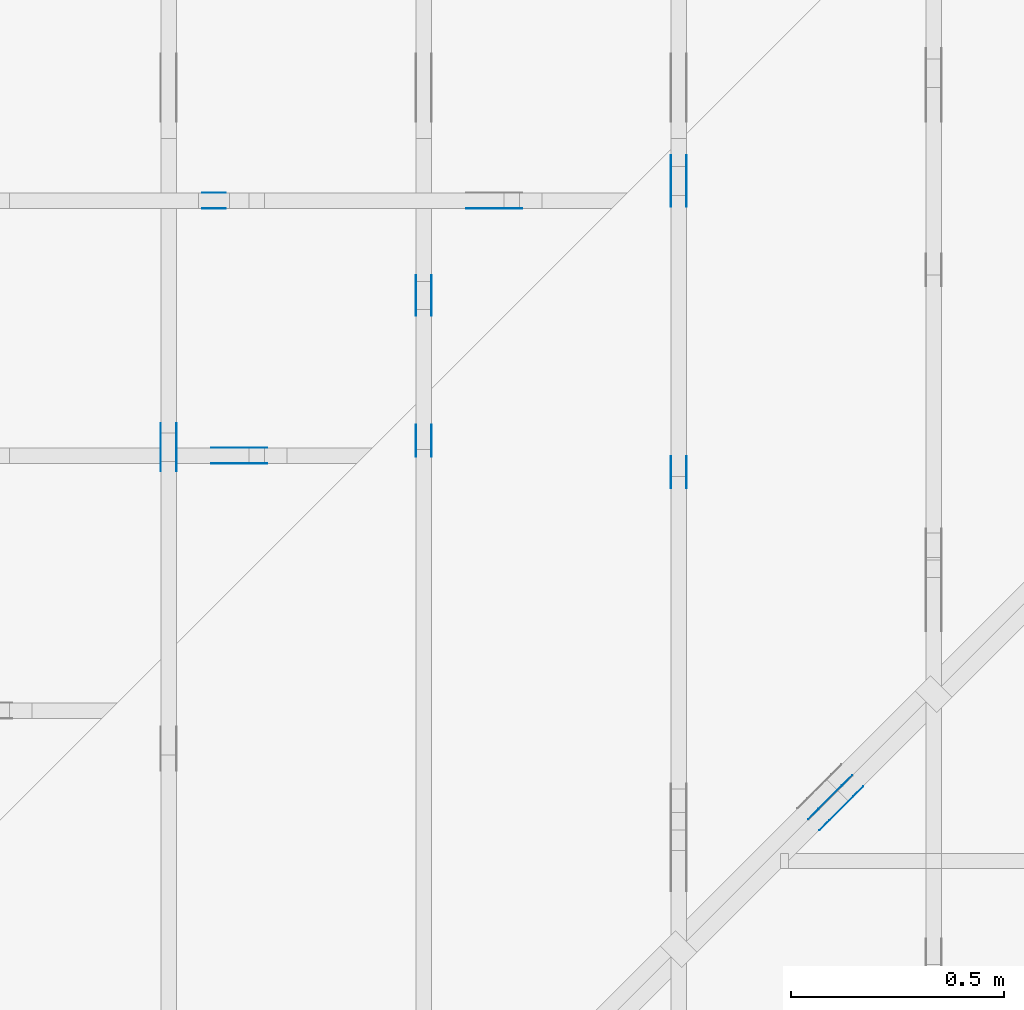
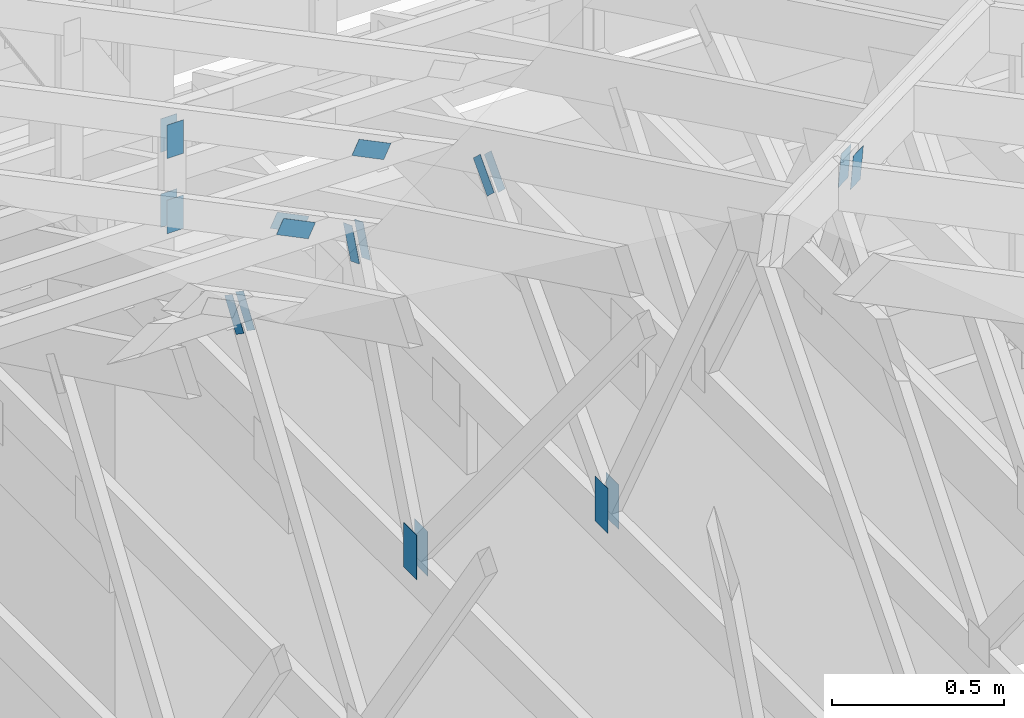
# One storey, part 122 of 159: 19 plates, 6 elements without a shape of their own.
"""IFC2X3 building model written with IfcOpenShell, lengths in millimetres."""

from ifc_helpers import new_model, si_unit, frame, origin, origin_with_axes, origin_2d, place, context, project, spatial, faceted_brep, element, aggregate, save


model = new_model("IFC2X3")

# Units and contexts
model_context = context("Model", 3, precision=1e-05, world=origin())
plan_context = context("Plan", 2, precision=1e-05, world=origin_2d())
ifc_project = project(units=[si_unit("LENGTHUNIT", "METRE", prefix="MILLI"), si_unit("AREAUNIT", "SQUARE_METRE"), si_unit("VOLUMEUNIT", "CUBIC_METRE"), si_unit("SOLIDANGLEUNIT", "STERADIAN"), si_unit("PLANEANGLEUNIT", "RADIAN"), si_unit("MASSUNIT", "GRAM"), si_unit("TIMEUNIT", "SECOND"), si_unit("THERMODYNAMICTEMPERATUREUNIT", "DEGREE_CELSIUS"), si_unit("LUMINOUSINTENSITYUNIT", "LUMEN")], contexts=[model_context, plan_context])

# Site, building, storey
site_placement = place(None, origin_with_axes())
site = spatial("IfcSite", under=ifc_project, at=site_placement, CompositionType="ELEMENT")
building_placement = place(site_placement, origin_with_axes())
building = spatial("IfcBuilding", under=site, at=building_placement, Name="Plan 1", CompositionType="ELEMENT")
storey_placement = place(building_placement, origin_with_axes())
storey = spatial("IfcBuildingStorey", under=building, at=storey_placement, Name="Etasje 1", CompositionType="ELEMENT", Elevation=0.0)

# Assembly, plates
assembly_1_placement = place(storey_placement, frame((16311.022261404749, -699.9989301294839, 1.1021457184401395e-15), z_axis=(1.0, -6.123031769111886e-17, 6.123031769111886e-17), x_axis=(6.123031769111886e-17, 1.0, 0.0)))
assembly_1 = element("IfcElementAssembly", 1, at=assembly_1_placement, inside=storey, Name="V8 (33)", AssemblyPlace="FACTORY", PredefinedType="TRUSS")
plate_1_placement = place(assembly_1_placement, frame((7426.87939453125, 291.4999999999999, 0.0), z_axis=(0.0, 0.0, 1.0), x_axis=(6.123031769111886e-17, 1.0, 0.0)))
plate_1 = element("IfcPlate", 2, at=plate_1_placement, Name="GNT100S 76x159", context=model_context, shape_type="Brep", body=[
    faceted_brep([(159.0000000000001, 76.0, 1.0), (1.1368683772161603e-13, 76.0, 1.0), (1.1368683772161603e-13, 0.0, 1.0), (159.0000000000001, 0.0, 1.0), (1.1368683772161603e-13, 76.0, 1.392216238198645e-29), (159.0000000000001, 76.0, 1.947124102577581e-14), (159.0000000000001, 0.0, 1.947124102577581e-14), (1.1368683772161603e-13, 0.0, 1.392216238198645e-29), (159.0, 5.9471509273759435e-05, 1.788345571668688e-30), (159.0, 5.9471509273820665e-05, 1.0), (1.1247455413666031e-32, 5.947150930302753e-05, 1.0), (0.0, 5.94715093029663e-05, 0.0), (159.0, 76.0000594715093, 0.0), (159.0, 76.0000594715093, 1.0), (159.0, 5.94715093029663e-05, 1.0), (159.0, 5.94715093029663e-05, 0.0), (2.4308653429145085e-63, 76.0000594715093, 0.0), (-3.7491518045553436e-33, 76.0000594715093, 1.0), (159.0, 76.00005947150929, 1.0), (159.0, 76.00005947150929, -7.888609052210118e-31), (7.282918816381915e-21, 5.94715093029663e-05, -4.45935432845692e-37), (6.123760060993524e-17, 5.94715093029663e-05, 1.0), (9.368245889660002e-15, 76.0000594715093, 1.0), (9.307015571968883e-15, 76.0000594715093, -5.698715202278451e-31)], [[[0, 1, 2, 3]], [[4, 5, 6, 7]], [[8, 9, 10, 11]], [[12, 13, 14, 15]], [[16, 17, 18, 19]], [[20, 21, 22, 23]]]),
])
plate_2_placement = place(assembly_1_placement, frame((7426.87939453125, 291.4999999999999, -37.0), z_axis=(0.0, 0.0, 1.0), x_axis=(6.123031769111886e-17, 1.0, 0.0)))
plate_2 = element("IfcPlate", 3, at=plate_2_placement, Name="GNT100S 76x159", context=model_context, shape_type="Brep", body=[
    faceted_brep([(159.0000000000001, 76.0, 1.0), (1.1368683772161603e-13, 76.0, 1.0), (1.1368683772161603e-13, 0.0, 1.0), (159.0000000000001, 0.0, 1.0), (1.1368683772161603e-13, 76.0, 1.392216238198645e-29), (159.0000000000001, 76.0, 1.947124102577581e-14), (159.0000000000001, 0.0, 1.947124102577581e-14), (1.1368683772161603e-13, 0.0, 1.392216238198645e-29), (159.0, 5.9471509273759435e-05, 1.788345571668688e-30), (159.0, 5.9471509273820665e-05, 1.0), (1.1247455413666031e-32, 5.947150930302753e-05, 1.0), (0.0, 5.94715093029663e-05, 0.0), (159.0, 76.0000594715093, 0.0), (159.0, 76.0000594715093, 1.0), (159.0, 5.94715093029663e-05, 1.0), (159.0, 5.94715093029663e-05, 0.0), (2.4308653429145085e-63, 76.0000594715093, 0.0), (-3.7491518045553436e-33, 76.0000594715093, 1.0), (159.0, 76.00005947150929, 1.0), (159.0, 76.00005947150929, -7.888609052210118e-31), (7.282918816381915e-21, 5.94715093029663e-05, -4.45935432845692e-37), (6.123760060993524e-17, 5.94715093029663e-05, 1.0), (9.368245889660002e-15, 76.0000594715093, 1.0), (9.307015571968883e-15, 76.0000594715093, -5.698715202278451e-31)], [[[0, 1, 2, 3]], [[4, 5, 6, 7]], [[8, 9, 10, 11]], [[12, 13, 14, 15]], [[16, 17, 18, 19]], [[20, 21, 22, 23]]]),
])
plate_3_placement = place(assembly_1_placement, frame((7727.3363223413935, 1322.4800851328964, 0.0), z_axis=(0.0, 0.0, 1.0), x_axis=(-0.3666406245078845, -0.9303626456712826, 0.0)))
plate_3 = element("IfcPlate", 4, at=plate_3_placement, Name="GNT100S 55x119", context=model_context, shape_type="Brep", body=[
    faceted_brep([(119.00014504609044, 55.00008577616154, 1.0), (0.0, 55.00008577616154, 1.0), (5.9450358548929216e-05, 0.00013461070739140268, 1.0), (119.00009092679011, 0.00013461070739140268, 1.0), (0.0, 55.00008577616154, 0.0), (119.00014504609044, 55.00008577616154, 1.4572833372922683e-14), (119.00009092679011, 0.0, 1.457282674543878e-14), (5.9450358548929216e-05, 0.0, 7.28032868160372e-21), (119.00002127778316, 0.00018937683582577298, -1.2175744154743796e-30), (119.00002127778316, 0.00018937683582583421, 1.0), (2.127778316207696e-05, 0.00018937683489645435, 1.0), (2.127778316207696e-05, 0.00018937683489639312, 0.0), (119.00002127778316, 55.000189376835806, 0.0), (119.00002127778316, 55.000189376835806, 1.0), (119.00002127778316, 0.00018937683580588782, 1.0), (119.00002127778316, 0.00018937683580588782, 0.0), (2.1277783162076958e-05, 55.000189376835806, 0.0), (2.1277783162076958e-05, 55.000189376835806, 1.0), (119.00002127778316, 55.0001893768358, 1.0), (119.00002127778316, 55.0001893768358, -3.944304526105059e-31), (2.127778316207698e-05, 0.00018937683489639312, -1.504632769052528e-36), (2.127778316213821e-05, 0.00018937683489639312, 1.0), (2.1277783168873547e-05, 55.000189376835806, 1.0), (2.1277783168812316e-05, 55.000189376835806, -4.124081810933378e-31)], [[[0, 1, 2, 3]], [[4, 5, 6, 7]], [[8, 9, 10, 11]], [[12, 13, 14, 15]], [[16, 17, 18, 19]], [[20, 21, 22, 23]]]),
])
plate_4_placement = place(assembly_1_placement, frame((7727.3363223413935, 1322.4800851328964, -36.99999999999999), z_axis=(0.0, 0.0, 1.0), x_axis=(-0.3666406245078845, -0.9303626456712826, 0.0)))
plate_4 = element("IfcPlate", 5, at=plate_4_placement, Name="GNT100S 55x119", context=model_context, shape_type="Brep", body=[
    faceted_brep([(119.00014504609044, 55.00008577616154, 1.0), (0.0, 55.00008577616154, 1.0), (5.9450358548929216e-05, 0.00013461070739140268, 1.0), (119.00009092679011, 0.00013461070739140268, 1.0), (0.0, 55.00008577616154, 0.0), (119.00014504609044, 55.00008577616154, 1.4572833372922683e-14), (119.00009092679011, 0.0, 1.457282674543878e-14), (5.9450358548929216e-05, 0.0, 7.28032868160372e-21), (119.00002127778316, 0.00018937683582577298, -1.2175744154743796e-30), (119.00002127778316, 0.00018937683582583421, 1.0), (2.127778316207696e-05, 0.00018937683489645435, 1.0), (2.127778316207696e-05, 0.00018937683489639312, 0.0), (119.00002127778316, 55.000189376835806, 0.0), (119.00002127778316, 55.000189376835806, 1.0), (119.00002127778316, 0.00018937683580588782, 1.0), (119.00002127778316, 0.00018937683580588782, 0.0), (2.1277783162076958e-05, 55.000189376835806, 0.0), (2.1277783162076958e-05, 55.000189376835806, 1.0), (119.00002127778316, 55.0001893768358, 1.0), (119.00002127778316, 55.0001893768358, -3.944304526105059e-31), (2.127778316207698e-05, 0.00018937683489639312, -1.504632769052528e-36), (2.127778316213821e-05, 0.00018937683489639312, 1.0), (2.1277783168873547e-05, 55.000189376835806, 1.0), (2.1277783168812316e-05, 55.000189376835806, -4.124081810933378e-31)], [[[0, 1, 2, 3]], [[4, 5, 6, 7]], [[8, 9, 10, 11]], [[12, 13, 14, 15]], [[16, 17, 18, 19]], [[20, 21, 22, 23]]]),
])
aggregate(assembly_1, [plate_1, plate_2, plate_3, plate_4])

assembly_2_placement = place(storey_placement, frame((16875.02226140475, -699.9989301294827, 1.1021457184401395e-15), z_axis=(-1.0, 1.836909530733566e-16, 6.123031769111886e-17), x_axis=(-1.836909530733566e-16, -1.0, 0.0)))
assembly_2 = element("IfcElementAssembly", 6, at=assembly_2_placement, inside=storey, Name="V7 (32)", AssemblyPlace="FACTORY", PredefinedType="TRUSS")
plate_5_placement = place(assembly_2_placement, frame((-8061.18067390642, 1150.2209577382325, 0.0), z_axis=(0.0, 0.0, 1.0), x_axis=(0.6848977524081679, -0.7286391896859791, 0.0)))
plate_5 = element("IfcPlate", 7, at=plate_5_placement, Name="GNT100S 55x119", context=model_context, shape_type="Brep", body=[
    faceted_brep([(119.00011485464893, 55.00006824185584, 1.0), (0.0, 55.00006824185584, 1.0), (1.4372830264619552e-05, 0.0, 1.0), (119.00004028226613, 0.0, 1.0), (0.0, 55.00006824185584, 0.0), (119.00011485464893, 55.00006824185584, 1.4572829675659574e-14), (119.00004028226613, 0.00010897796255449066, 1.4572820543478193e-14), (1.4372830264619552e-05, 0.00010897796255449066, 1.7601059264463663e-21), (119.0000768655018, 0.00010936123720063465, 3.8944725934268084e-30), (119.0000768655018, 0.00010936123720069588, 1.0), (7.686550179641927e-05, 0.00010936123817379419, 1.0), (7.686550179641927e-05, 0.00010936123817373296, 3.009265538105056e-36), (119.0000768655018, 55.000109361238174, 0.0), (119.0000768655018, 55.000109361238174, 1.0), (119.0000768655018, 0.0001093612372642383, 1.0), (119.0000768655018, 0.0001093612372642383, 0.0), (7.686550179641925e-05, 55.000109361237264, 0.0), (7.686550179641925e-05, 55.000109361237264, 1.0), (119.0000768655018, 55.00010936123818, 1.0), (119.0000768655018, 55.00010936123818, 3.944304526105059e-31), (7.686550179641928e-05, 0.000109361238173733, -7.52316384526264e-37), (7.686550179648051e-05, 0.000109361238173733, 1.0), (7.686550180321585e-05, 55.000109361237264, 1.0), (7.686550180315462e-05, 55.000109361237264, -4.124078049351455e-31)], [[[0, 1, 2, 3]], [[4, 5, 6, 7]], [[8, 9, 10, 11]], [[12, 13, 14, 15]], [[16, 17, 18, 19]], [[20, 21, 22, 23]]]),
])
plate_6_placement = place(assembly_2_placement, frame((-8061.18067390642, 1150.2209577382325, -37.00000000000001), z_axis=(0.0, 0.0, 1.0), x_axis=(0.6848977524081679, -0.7286391896859791, 0.0)))
plate_6 = element("IfcPlate", 8, at=plate_6_placement, Name="GNT100S 55x119", context=model_context, shape_type="Brep", body=[
    faceted_brep([(119.00011485464893, 55.00006824185584, 1.0), (0.0, 55.00006824185584, 1.0), (1.4372830264619552e-05, 0.0, 1.0), (119.00004028226613, 0.0, 1.0), (0.0, 55.00006824185584, 0.0), (119.00011485464893, 55.00006824185584, 1.4572829675659574e-14), (119.00004028226613, 0.00010897796255449066, 1.4572820543478193e-14), (1.4372830264619552e-05, 0.00010897796255449066, 1.7601059264463663e-21), (119.0000768655018, 0.00010936123720063465, 3.8944725934268084e-30), (119.0000768655018, 0.00010936123720069588, 1.0), (7.686550179641927e-05, 0.00010936123817379419, 1.0), (7.686550179641927e-05, 0.00010936123817373296, 3.009265538105056e-36), (119.0000768655018, 55.000109361238174, 0.0), (119.0000768655018, 55.000109361238174, 1.0), (119.0000768655018, 0.0001093612372642383, 1.0), (119.0000768655018, 0.0001093612372642383, 0.0), (7.686550179641925e-05, 55.000109361237264, 0.0), (7.686550179641925e-05, 55.000109361237264, 1.0), (119.0000768655018, 55.00010936123818, 1.0), (119.0000768655018, 55.00010936123818, 3.944304526105059e-31), (7.686550179641928e-05, 0.000109361238173733, -7.52316384526264e-37), (7.686550179648051e-05, 0.000109361238173733, 1.0), (7.686550180321585e-05, 55.000109361237264, 1.0), (7.686550180315462e-05, 55.000109361237264, -4.124078049351455e-31)], [[[0, 1, 2, 3]], [[4, 5, 6, 7]], [[8, 9, 10, 11]], [[12, 13, 14, 15]], [[16, 17, 18, 19]], [[20, 21, 22, 23]]]),
])
plate_7_placement = place(assembly_2_placement, frame((-7276.765625, 291.4999999999998, 0.0), z_axis=(0.0, 0.0, 1.0), x_axis=(6.123031769111886e-17, 1.0, 0.0)))
plate_7 = element("IfcPlate", 9, at=plate_7_placement, Name="GNT100S 76x159", context=model_context, shape_type="Brep", body=[
    faceted_brep([(159.00000000000023, 76.0, 1.0), (2.2737367544323206e-13, 76.0, 1.0), (2.2737367544323206e-13, 0.0, 1.0), (159.00000000000023, 0.0, 1.0), (2.2737367544323206e-13, 76.0, 2.78443247639729e-29), (159.00000000000023, 76.0, 1.9471241025775827e-14), (159.00000000000023, 0.0, 1.9471241025775827e-14), (2.2737367544323206e-13, 0.0, 2.78443247639729e-29), (159.0, 0.0001630968781390827, 1.7883448193523036e-30), (159.0, 0.00016309687813914392, 1.0), (1.1247455413666031e-32, 0.00016309687816835078, 1.0), (0.0, 0.00016309687816828955, 0.0), (159.0, 76.00016309687817, 0.0), (159.0, 76.00016309687817, 1.0), (159.0, 0.00016309687816828955, 1.0), (159.0, 0.00016309687816828955, 0.0), (0.0, 76.00016309687817, 0.0), (-3.7491518045553436e-33, 76.00016309687817, 1.0), (159.0, 76.00016309687815, 1.0), (159.0, 76.00016309687815, -7.888609052210118e-31), (1.9972947329348155e-20, 0.00016309687816828955, -1.2229499102039716e-36), (6.125029063844821e-17, 0.00016309687816828955, 1.0), (9.368258579688515e-15, 76.00016309687817, 1.0), (9.307028261997396e-15, 76.00016309687817, -5.698722972423224e-31)], [[[0, 1, 2, 3]], [[4, 5, 6, 7]], [[8, 9, 10, 11]], [[12, 13, 14, 15]], [[16, 17, 18, 19]], [[20, 21, 22, 23]]]),
])
plate_8_placement = place(assembly_2_placement, frame((-7276.765625, 291.4999999999998, -37.0), z_axis=(0.0, 0.0, 1.0), x_axis=(6.123031769111886e-17, 1.0, 0.0)))
plate_8 = element("IfcPlate", 10, at=plate_8_placement, Name="GNT100S 76x159", context=model_context, shape_type="Brep", body=[
    faceted_brep([(159.00000000000023, 76.0, 1.0), (2.2737367544323206e-13, 76.0, 1.0), (2.2737367544323206e-13, 0.0, 1.0), (159.00000000000023, 0.0, 1.0), (2.2737367544323206e-13, 76.0, 2.78443247639729e-29), (159.00000000000023, 76.0, 1.9471241025775827e-14), (159.00000000000023, 0.0, 1.9471241025775827e-14), (2.2737367544323206e-13, 0.0, 2.78443247639729e-29), (159.0, 0.0001630968781390827, 1.7883448193523036e-30), (159.0, 0.00016309687813914392, 1.0), (1.1247455413666031e-32, 0.00016309687816835078, 1.0), (0.0, 0.00016309687816828955, 0.0), (159.0, 76.00016309687817, 0.0), (159.0, 76.00016309687817, 1.0), (159.0, 0.00016309687816828955, 1.0), (159.0, 0.00016309687816828955, 0.0), (0.0, 76.00016309687817, 0.0), (-3.7491518045553436e-33, 76.00016309687817, 1.0), (159.0, 76.00016309687815, 1.0), (159.0, 76.00016309687815, -7.888609052210118e-31), (1.9972947329348155e-20, 0.00016309687816828955, -1.2229499102039716e-36), (6.125029063844821e-17, 0.00016309687816828955, 1.0), (9.368258579688515e-15, 76.00016309687817, 1.0), (9.307028261997396e-15, 76.00016309687817, -5.698722972423224e-31)], [[[0, 1, 2, 3]], [[4, 5, 6, 7]], [[8, 9, 10, 11]], [[12, 13, 14, 15]], [[16, 17, 18, 19]], [[20, 21, 22, 23]]]),
])
aggregate(assembly_2, [plate_5, plate_6, plate_7, plate_8])

assembly_3_placement = place(storey_placement, frame((21074.556818978763, 9725.45584412271, 2.204291436880279e-15), z_axis=(-0.7071067811865471, 0.7071067811865479, 6.123031769111886e-17), x_axis=(-0.7071067811865479, -0.7071067811865471, 0.0)))
assembly_3 = element("IfcElementAssembly", 11, at=assembly_3_placement, inside=storey, Name="GR1 (36)", AssemblyPlace="FACTORY", PredefinedType="TRUSS")
plate_9_placement = place(assembly_3_placement, frame((5405.349966255167, 1839.0221714793984, -35.99999999999999), z_axis=(0.0, 0.0, 1.0), x_axis=(0.9453579955214152, 0.32603413978252627, 0.0)))
plate_9 = element("IfcPlate", 12, at=plate_9_placement, Name="GNT100S 103x119", context=model_context, shape_type="Brep", body=[
    faceted_brep([(119.00006868466426, 102.99996388448972, 1.0), (9.843365569395246e-05, 102.99996388448972, 1.0), (0.0001389961080349167, 0.0, 1.0), (119.0001092471175, 0.0, 1.0), (9.843365569395246e-05, 102.99996388448972, 1.205424801927784e-20), (119.00006868466426, 102.99996388448972, 1.4572824021653914e-14), (119.0001092471175, 4.524020664575801e-05, 1.4572828988957714e-14), (0.0001389961080349167, 4.524020664575801e-05, 1.7021551705614056e-20), (119.0, 4.315270027833824e-05, 1.338447208185253e-30), (119.0, 4.315270027839947e-05, 1.0), (1.1247455413666031e-32, 4.3152700300258697e-05, 1.0), (0.0, 4.3152700300197466e-05, 0.0), (119.0, 103.0000431527003, 5.522026336547083e-29), (119.0, 103.0000431527003, 1.0), (119.0, 4.3152700300197466e-05, 1.0), (119.0, 4.3152700300197466e-05, 0.0), (0.0, 103.0000431527003, 0.0), (-3.7491518045553436e-33, 103.0000431527003, 1.0), (118.99999999999909, 103.00004315270029, 1.0), (118.99999999999909, 103.00004315270029, -7.888609052210118e-31), (5.284507097221462e-21, 4.3152700300197466e-05, -3.235720484038425e-37), (6.123560219821608e-17, 4.3152700300197466e-05, 1.0), (1.2674681046568702e-14, 103.0000431527003, 1.0), (1.2613450728877583e-14, 103.0000431527003, -7.723255953104492e-31)], [[[0, 1, 2, 3]], [[4, 5, 6, 7]], [[8, 9, 10, 11]], [[12, 13, 14, 15]], [[16, 17, 18, 19]], [[20, 21, 22, 23]]]),
])
plate_10_placement = place(assembly_3_placement, frame((5405.349966255167, 1839.0221714793984, -73.0), z_axis=(0.0, 0.0, 1.0), x_axis=(0.9453579955214152, 0.32603413978252627, 0.0)))
plate_10 = element("IfcPlate", 13, at=plate_10_placement, Name="GNT100S 103x119", context=model_context, shape_type="Brep", body=[
    faceted_brep([(119.00006868466426, 102.99996388448972, 1.0), (9.843365569395246e-05, 102.99996388448972, 1.0), (0.0001389961080349167, 0.0, 1.0), (119.0001092471175, 0.0, 1.0), (9.843365569395246e-05, 102.99996388448972, 1.205424801927784e-20), (119.00006868466426, 102.99996388448972, 1.4572824021653914e-14), (119.0001092471175, 4.524020664575801e-05, 1.4572828988957714e-14), (0.0001389961080349167, 4.524020664575801e-05, 1.7021551705614056e-20), (119.0, 4.315270027833824e-05, 1.338447208185253e-30), (119.0, 4.315270027839947e-05, 1.0), (1.1247455413666031e-32, 4.3152700300258697e-05, 1.0), (0.0, 4.3152700300197466e-05, 0.0), (119.0, 103.0000431527003, 5.522026336547083e-29), (119.0, 103.0000431527003, 1.0), (119.0, 4.3152700300197466e-05, 1.0), (119.0, 4.3152700300197466e-05, 0.0), (0.0, 103.0000431527003, 0.0), (-3.7491518045553436e-33, 103.0000431527003, 1.0), (118.99999999999909, 103.00004315270029, 1.0), (118.99999999999909, 103.00004315270029, -7.888609052210118e-31), (5.284507097221462e-21, 4.3152700300197466e-05, -3.235720484038425e-37), (6.123560219821608e-17, 4.3152700300197466e-05, 1.0), (1.2674681046568702e-14, 103.0000431527003, 1.0), (1.2613450728877583e-14, 103.0000431527003, -7.723255953104492e-31)], [[[0, 1, 2, 3]], [[4, 5, 6, 7]], [[8, 9, 10, 11]], [[12, 13, 14, 15]], [[16, 17, 18, 19]], [[20, 21, 22, 23]]]),
])
aggregate(assembly_3, [plate_9, plate_10])

assembly_4_placement = place(storey_placement, frame((12446.012607049342, 7236.0000560521385, 1312.9938842936408), z_axis=(0.0, -1.0, 6.123031769111886e-17), x_axis=(1.0, 0.0, 0.0)))
assembly_4 = element("IfcElementAssembly", 14, at=assembly_4_placement, inside=storey, Name="Tr3 (84)", AssemblyPlace="FACTORY", PredefinedType="TRUSS")
plate_11_placement = place(assembly_4_placement, frame((4078.826416015625, 87.8545837402346, 0.0), z_axis=(0.0, 0.0, 1.0), x_axis=(-0.8987940462991675, 0.4383711467890765, 0.0)))
plate_11 = element("IfcPlate", 15, at=plate_11_placement, Name="GNT100S 55x119", context=model_context, shape_type="Brep", body=[
    faceted_brep([(118.99998948302118, 55.000081238989424, 1.0), (0.0001635712847019022, 55.000081238989424, 1.0), (0.0, 0.0, 1.0), (119.00004701613034, 0.0, 1.0), (0.0001635712847019022, 55.000081238989424, 2.0031043454883843e-20), (118.99998948302118, 55.000081238989424, 1.457281432257038e-14), (119.00004701613034, 2.098981917697529e-05, 1.4572821368111483e-14), (0.0, 2.098981917697529e-05, 0.0), (119.00007991769235, 4.083752830953519e-05, 1.3384479605016376e-30), (119.00007991769235, 4.083752830959642e-05, 1.0), (7.991769234649837e-05, 4.083752833145564e-05, 1.0), (7.991769234649837e-05, 4.083752833139441e-05, 7.52316384526264e-37), (119.00007991769235, 55.000040837528104, 2.68212707775144e-29), (119.00007991769235, 55.000040837528104, 1.0), (119.00007991769235, 4.0837528331394424e-05, 1.0), (119.00007991769235, 4.0837528331394424e-05, 0.0), (7.991769234649836e-05, 55.00004083752833, 0.0), (7.991769234649836e-05, 55.00004083752833, 1.0), (119.00007991769189, 55.00004083752811, 1.0), (119.00007991769189, 55.00004083752811, 3.944304526105059e-31), (7.991769234649837e-05, 4.0837528331394424e-05, 0.0), (7.99176923465596e-05, 4.0837528331394424e-05, 1.0), (7.991769235329494e-05, 55.00004083752833, 1.0), (7.99176923532337e-05, 55.00004083752833, -4.12407052618761e-31)], [[[0, 1, 2, 3]], [[4, 5, 6, 7]], [[8, 9, 10, 11]], [[12, 13, 14, 15]], [[16, 17, 18, 19]], [[20, 21, 22, 23]]]),
])
plate_12_placement = place(assembly_4_placement, frame((3326.5, 415.7619323730469, 0.0), z_axis=(0.0, 0.0, 1.0), x_axis=(6.123031769111886e-17, -1.0, 0.0)))
plate_12 = element("IfcPlate", 16, at=plate_12_placement, Name="GNT100S 55x119", context=model_context, shape_type="Brep", body=[
    faceted_brep([(119.0, 55.0, 1.0), (0.0, 55.0, 1.0), (0.0, 0.0, 1.0), (119.0, 0.0, 1.0), (0.0, 55.0, 0.0), (119.0, 55.0, 1.457281561048629e-14), (119.0, 0.0, 1.457281561048629e-14), (0.0, 0.0, 0.0), (119.00000570882497, 5.605214071325966e-05, 1.3384475843434453e-30), (119.00000570882497, 5.605214071332089e-05, 1.0), (5.708824971861759e-06, 5.605214073518011e-05, 1.0), (5.708824971861759e-06, 5.605214073511888e-05, 0.0), (119.00000570882497, 55.000056052140735, 0.0), (119.00000570882497, 55.000056052140735, 1.0), (119.00000570882497, 5.605214073511888e-05, 1.0), (119.00000570882497, 5.605214073511888e-05, 0.0), (5.708824971861759e-06, 55.000056052140735, 0.0), (5.708824971861759e-06, 55.000056052140735, 1.0), (119.00000570882497, 55.00005605214073, 1.0), (119.00000570882497, 55.00005605214073, -3.944304526105059e-31), (5.708824971861766e-06, 5.605214073511888e-05, -4.231779662960235e-37), (5.708824971922996e-06, 5.605214073511888e-05, 1.0), (5.708824978658331e-06, 55.000056052140735, 1.0), (5.708824978597101e-06, 55.000056052140735, -4.12407099638535e-31)], [[[0, 1, 2, 3]], [[4, 5, 6, 7]], [[8, 9, 10, 11]], [[12, 13, 14, 15]], [[16, 17, 18, 19]], [[20, 21, 22, 23]]]),
])
plate_13_placement = place(assembly_4_placement, frame((3326.5, 415.7619323730469, -37.0), z_axis=(0.0, 0.0, 1.0), x_axis=(6.123031769111886e-17, -1.0, 0.0)))
plate_13 = element("IfcPlate", 17, at=plate_13_placement, Name="GNT100S 55x119", context=model_context, shape_type="Brep", body=[
    faceted_brep([(119.0, 55.0, 1.0), (0.0, 55.0, 1.0), (0.0, 0.0, 1.0), (119.0, 0.0, 1.0), (0.0, 55.0, 0.0), (119.0, 55.0, 1.457281561048629e-14), (119.0, 0.0, 1.457281561048629e-14), (0.0, 0.0, 0.0), (119.00000570882497, 5.605214071325966e-05, 1.3384475843434453e-30), (119.00000570882497, 5.605214071332089e-05, 1.0), (5.708824971861759e-06, 5.605214073518011e-05, 1.0), (5.708824971861759e-06, 5.605214073511888e-05, 0.0), (119.00000570882497, 55.000056052140735, 0.0), (119.00000570882497, 55.000056052140735, 1.0), (119.00000570882497, 5.605214073511888e-05, 1.0), (119.00000570882497, 5.605214073511888e-05, 0.0), (5.708824971861759e-06, 55.000056052140735, 0.0), (5.708824971861759e-06, 55.000056052140735, 1.0), (119.00000570882497, 55.00005605214073, 1.0), (119.00000570882497, 55.00005605214073, -3.944304526105059e-31), (5.708824971861766e-06, 5.605214073511888e-05, -4.231779662960235e-37), (5.708824971922996e-06, 5.605214073511888e-05, 1.0), (5.708824978658331e-06, 55.000056052140735, 1.0), (5.708824978597101e-06, 55.000056052140735, -4.12407099638535e-31)], [[[0, 1, 2, 3]], [[4, 5, 6, 7]], [[8, 9, 10, 11]], [[12, 13, 14, 15]], [[16, 17, 18, 19]], [[20, 21, 22, 23]]]),
])
plate_14_placement = place(assembly_4_placement, frame((3381.5000560521407, 29.720829010009762, 0.0), z_axis=(0.0, 0.0, 1.0), x_axis=(6.123031769111886e-17, 1.0, 0.0)))
plate_14 = element("IfcPlate", 18, at=plate_14_placement, Name="GNT100S 55x119", context=model_context, shape_type="Brep", body=[
    faceted_brep([(118.99999618530273, 55.000056052140735, 1.0), (0.0, 55.000056052140735, 1.0), (3.552713678800501e-15, 5.605214073511888e-05, 1.0), (118.99999618530273, 5.605214073511888e-05, 1.0), (0.0, 55.000056052140735, 0.0), (118.99999618530273, 55.000056052140735, 1.457281514333604e-14), (118.99999618530273, 5.605214073511888e-05, 1.457281514333604e-14), (3.552713678800501e-15, 5.605214073511888e-05, 4.350675744370766e-31), (119.0000000204891, -2.1859223419493096e-14, 1.3384471944567079e-30), (119.0000000204891, -2.1797993101801977e-14, 1.0), (2.0489100194254206e-08, 6.123031392745652e-17, 1.0), (2.0489100194254206e-08, -3.763662342298051e-24, 2.304502409010102e-40), (119.0000000204891, 55.0, 0.0), (119.0000000204891, 55.0, 1.0), (119.0000000204891, 0.0, 1.0), (119.0000000204891, 0.0, 0.0), (2.0489100194254206e-08, 55.0, 0.0), (2.0489100194254206e-08, 55.0, 1.0), (119.0000000204891, 54.99999999999999, 1.0), (119.0000000204891, 54.99999999999999, -3.944304526105059e-31), (2.0489100194254206e-08, 0.0, 0.0), (2.0489100255484524e-08, -7.498303609110687e-33, 1.0), (2.048910699081947e-08, 55.0, 1.0), (2.0489106929589152e-08, 55.0, -4.124066985010878e-31)], [[[0, 1, 2, 3]], [[4, 5, 6, 7]], [[8, 9, 10, 11]], [[12, 13, 14, 15]], [[16, 17, 18, 19]], [[20, 21, 22, 23]]]),
])
plate_15_placement = place(assembly_4_placement, frame((3381.5000560521407, 29.720829010009762, -37.0), z_axis=(0.0, 0.0, 1.0), x_axis=(6.123031769111886e-17, 1.0, 0.0)))
plate_15 = element("IfcPlate", 19, at=plate_15_placement, Name="GNT100S 55x119", context=model_context, shape_type="Brep", body=[
    faceted_brep([(118.99999618530273, 55.000056052140735, 1.0), (0.0, 55.000056052140735, 1.0), (3.552713678800501e-15, 5.605214073511888e-05, 1.0), (118.99999618530273, 5.605214073511888e-05, 1.0), (0.0, 55.000056052140735, 0.0), (118.99999618530273, 55.000056052140735, 1.457281514333604e-14), (118.99999618530273, 5.605214073511888e-05, 1.457281514333604e-14), (3.552713678800501e-15, 5.605214073511888e-05, 4.350675744370766e-31), (119.0000000204891, -2.1859223419493096e-14, 1.3384471944567079e-30), (119.0000000204891, -2.1797993101801977e-14, 1.0), (2.0489100194254206e-08, 6.123031392745652e-17, 1.0), (2.0489100194254206e-08, -3.763662342298051e-24, 2.304502409010102e-40), (119.0000000204891, 55.0, 0.0), (119.0000000204891, 55.0, 1.0), (119.0000000204891, 0.0, 1.0), (119.0000000204891, 0.0, 0.0), (2.0489100194254206e-08, 55.0, 0.0), (2.0489100194254206e-08, 55.0, 1.0), (119.0000000204891, 54.99999999999999, 1.0), (119.0000000204891, 54.99999999999999, -3.944304526105059e-31), (2.0489100194254206e-08, 0.0, 0.0), (2.0489100255484524e-08, -7.498303609110687e-33, 1.0), (2.048910699081947e-08, 55.0, 1.0), (2.0489106929589152e-08, 55.0, -4.124066985010878e-31)], [[[0, 1, 2, 3]], [[4, 5, 6, 7]], [[8, 9, 10, 11]], [[12, 13, 14, 15]], [[16, 17, 18, 19]], [[20, 21, 22, 23]]]),
])
aggregate(assembly_4, [plate_11, plate_12, plate_13, plate_14, plate_15])

assembly_5_placement = place(storey_placement, frame((13046.012612936298, 6636.000050165183, 1605.6334403044173), z_axis=(0.0, -1.0, 6.123031769111886e-17), x_axis=(1.0, 0.0, 0.0)))
assembly_5 = element("IfcElementAssembly", 20, at=assembly_5_placement, inside=storey, Name="Tr4 (108)", AssemblyPlace="FACTORY", PredefinedType="TRUSS")
plate_16_placement = place(assembly_5_placement, frame((2878.826416015625, 87.85458374023438, 0.0), z_axis=(0.0, 0.0, 1.0), x_axis=(-0.8987940462991675, 0.4383711467890765, 0.0)))
plate_16 = element("IfcPlate", 21, at=plate_16_placement, Name="GNT100S 55x119", context=model_context, shape_type="Brep", body=[
    faceted_brep([(118.99998948302164, 55.000081238989424, 1.0), (0.0001635712847019022, 55.000081238989424, 1.0), (0.0, 0.0, 1.0), (119.00004701613034, 0.0, 1.0), (0.0001635712847019022, 55.000081238989424, 2.0031043454883843e-20), (118.99998948302164, 55.000081238989424, 1.4572814322570436e-14), (119.00004701613034, 2.098981917697529e-05, 1.4572821368111483e-14), (0.0, 2.098981917697529e-05, 0.0), (119.00009050073231, 4.599922203264546e-05, 3.5954516570183078e-31), (119.00009050073231, 4.599922203270669e-05, 1.0), (9.050073276739566e-05, 4.599922226595238e-05, 1.0), (9.050073276739566e-05, 4.599922226589115e-05, 0.0), (119.00009050073231, 55.00004599922204, -2.68212707775144e-29), (119.00009050073231, 55.00004599922204, 1.0), (119.00009050073231, 4.599922203851747e-05, 1.0), (119.00009050073231, 4.599922203851747e-05, 0.0), (9.050073322214303e-05, 55.00004599922204, 0.0), (9.050073322214303e-05, 55.00004599922204, 1.0), (119.00009050073277, 55.00004599922203, 1.0), (119.00009050073277, 55.00004599922203, -3.944304526105059e-31), (9.050073276739568e-05, 4.599922226589115e-05, 7.52316384526264e-37), (9.05007327674569e-05, 4.599922226589115e-05, 1.0), (9.050073321384056e-05, 55.00004599922204, 1.0), (9.050073321377933e-05, 55.00004599922204, 5.121122953764113e-31)], [[[0, 1, 2, 3]], [[4, 5, 6, 7]], [[8, 9, 10, 11]], [[12, 13, 14, 15]], [[16, 17, 18, 19]], [[20, 21, 22, 23]]]),
])
plate_17_placement = place(assembly_5_placement, frame((2878.826416015625, 87.85458374023438, -37.0), z_axis=(0.0, 0.0, 1.0), x_axis=(-0.8987940462991675, 0.4383711467890765, 0.0)))
plate_17 = element("IfcPlate", 22, at=plate_17_placement, Name="GNT100S 55x119", context=model_context, shape_type="Brep", body=[
    faceted_brep([(118.99998948302164, 55.000081238989424, 1.0), (0.0001635712847019022, 55.000081238989424, 1.0), (0.0, 0.0, 1.0), (119.00004701613034, 0.0, 1.0), (0.0001635712847019022, 55.000081238989424, 2.0031043454883843e-20), (118.99998948302164, 55.000081238989424, 1.4572814322570436e-14), (119.00004701613034, 2.098981917697529e-05, 1.4572821368111483e-14), (0.0, 2.098981917697529e-05, 0.0), (119.00009050073231, 4.599922203264546e-05, 3.5954516570183078e-31), (119.00009050073231, 4.599922203270669e-05, 1.0), (9.050073276739566e-05, 4.599922226595238e-05, 1.0), (9.050073276739566e-05, 4.599922226589115e-05, 0.0), (119.00009050073231, 55.00004599922204, -2.68212707775144e-29), (119.00009050073231, 55.00004599922204, 1.0), (119.00009050073231, 4.599922203851747e-05, 1.0), (119.00009050073231, 4.599922203851747e-05, 0.0), (9.050073322214303e-05, 55.00004599922204, 0.0), (9.050073322214303e-05, 55.00004599922204, 1.0), (119.00009050073277, 55.00004599922203, 1.0), (119.00009050073277, 55.00004599922203, -3.944304526105059e-31), (9.050073276739568e-05, 4.599922226589115e-05, 7.52316384526264e-37), (9.05007327674569e-05, 4.599922226589115e-05, 1.0), (9.050073321384056e-05, 55.00004599922204, 1.0), (9.050073321377933e-05, 55.00004599922204, 5.121122953764113e-31)], [[[0, 1, 2, 3]], [[4, 5, 6, 7]], [[8, 9, 10, 11]], [[12, 13, 14, 15]], [[16, 17, 18, 19]], [[20, 21, 22, 23]]]),
])
aggregate(assembly_5, [plate_16, plate_17])

assembly_6_placement = place(storey_placement, frame((15675.02226140475, -699.9989301294845, 1.1021457184401395e-15), z_axis=(-1.0, 1.836909530733566e-16, 6.123031769111886e-17), x_axis=(-1.836909530733566e-16, -1.0, 0.0)))
assembly_6 = element("IfcElementAssembly", 23, at=assembly_6_placement, inside=storey, Name="T7 (111)", AssemblyPlace="FACTORY", PredefinedType="TRUSS")
plate_18_placement = place(assembly_6_placement, frame((-7430.1562647054525, 1464.8788056966719, 0.0), z_axis=(0.0, 0.0, 1.0), x_axis=(0.56424750500642, -0.8256056886274646, 0.0)))
plate_18 = element("IfcPlate", 24, at=plate_18_placement, Name="GNT100S 55x119", context=model_context, shape_type="Brep", body=[
    faceted_brep([(119.00002539657544, 54.99988487959854, 1.0), (0.0, 54.99988487959854, 1.0), (2.606205816846341e-05, 0.0, 1.0), (119.0000514586336, 0.0, 1.0), (0.0, 54.99988487959854, 0.0), (119.00002539657544, 54.99988487959854, 1.4572818720567054e-14), (119.0000514586336, 4.891776097792899e-05, 1.4572821912143256e-14), (2.606205816846341e-05, 4.891776097792899e-05, 3.191576202678868e-21), (119.0000637359608, 2.5329963114896162e-05, 1.3384479605016376e-30), (119.0000637359608, 2.5329963114957392e-05, 1.0), (6.373596079356503e-05, 2.5329963136816616e-05, 1.0), (6.373596079356503e-05, 2.5329963136755386e-05, 7.52316384526264e-37), (119.0000637359608, 55.00002532996314, 0.0), (119.0000637359608, 55.00002532996314, 1.0), (119.0000637359608, 2.5329963136755396e-05, 1.0), (119.0000637359608, 2.5329963136755396e-05, 0.0), (6.373596079356503e-05, 55.000025329964046, 0.0), (6.373596079356503e-05, 55.000025329964046, 1.0), (119.0000637359608, 55.000025329963165, 1.0), (119.0000637359608, 55.000025329963165, 2.3665827156630354e-30), (6.373596079356503e-05, 2.5329963136755396e-05, 0.0), (6.373596079362626e-05, 2.5329963136755396e-05, 1.0), (6.373596080036159e-05, 55.000025329964046, 1.0), (6.373596080030036e-05, 55.000025329964046, -4.12407052618761e-31)], [[[0, 1, 2, 3]], [[4, 5, 6, 7]], [[8, 9, 10, 11]], [[12, 13, 14, 15]], [[16, 17, 18, 19]], [[20, 21, 22, 23]]]),
])
plate_19_placement = place(assembly_6_placement, frame((-7430.1562647054525, 1464.8788056966719, -37.0), z_axis=(0.0, 0.0, 1.0), x_axis=(0.56424750500642, -0.8256056886274646, 0.0)))
plate_19 = element("IfcPlate", 25, at=plate_19_placement, Name="GNT100S 55x119", context=model_context, shape_type="Brep", body=[
    faceted_brep([(119.00002539657544, 54.99988487959854, 1.0), (0.0, 54.99988487959854, 1.0), (2.606205816846341e-05, 0.0, 1.0), (119.0000514586336, 0.0, 1.0), (0.0, 54.99988487959854, 0.0), (119.00002539657544, 54.99988487959854, 1.4572818720567054e-14), (119.0000514586336, 4.891776097792899e-05, 1.4572821912143256e-14), (2.606205816846341e-05, 4.891776097792899e-05, 3.191576202678868e-21), (119.0000637359608, 2.5329963114896162e-05, 1.3384479605016376e-30), (119.0000637359608, 2.5329963114957392e-05, 1.0), (6.373596079356503e-05, 2.5329963136816616e-05, 1.0), (6.373596079356503e-05, 2.5329963136755386e-05, 7.52316384526264e-37), (119.0000637359608, 55.00002532996314, 0.0), (119.0000637359608, 55.00002532996314, 1.0), (119.0000637359608, 2.5329963136755396e-05, 1.0), (119.0000637359608, 2.5329963136755396e-05, 0.0), (6.373596079356503e-05, 55.000025329964046, 0.0), (6.373596079356503e-05, 55.000025329964046, 1.0), (119.0000637359608, 55.000025329963165, 1.0), (119.0000637359608, 55.000025329963165, 2.3665827156630354e-30), (6.373596079356503e-05, 2.5329963136755396e-05, 0.0), (6.373596079362626e-05, 2.5329963136755396e-05, 1.0), (6.373596080036159e-05, 55.000025329964046, 1.0), (6.373596080030036e-05, 55.000025329964046, -4.12407052618761e-31)], [[[0, 1, 2, 3]], [[4, 5, 6, 7]], [[8, 9, 10, 11]], [[12, 13, 14, 15]], [[16, 17, 18, 19]], [[20, 21, 22, 23]]]),
])
aggregate(assembly_6, [plate_18, plate_19])

save(model, "model.ifc")
